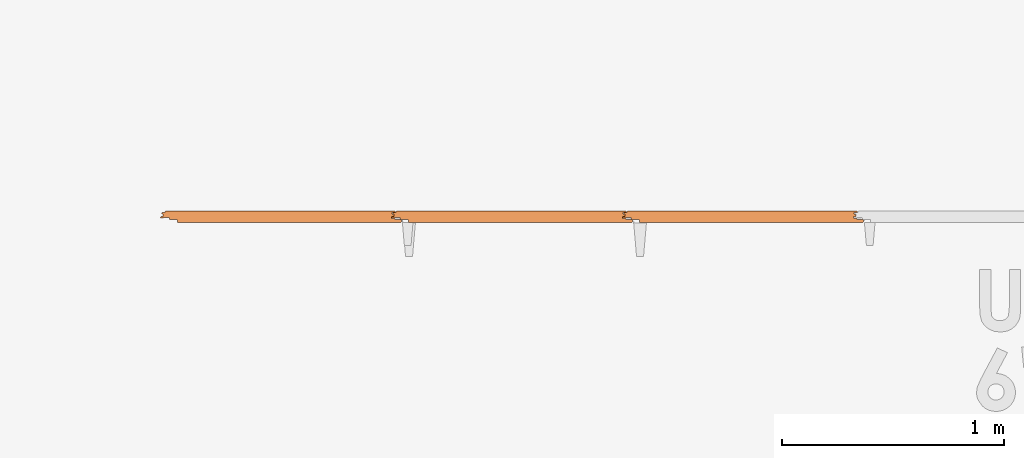
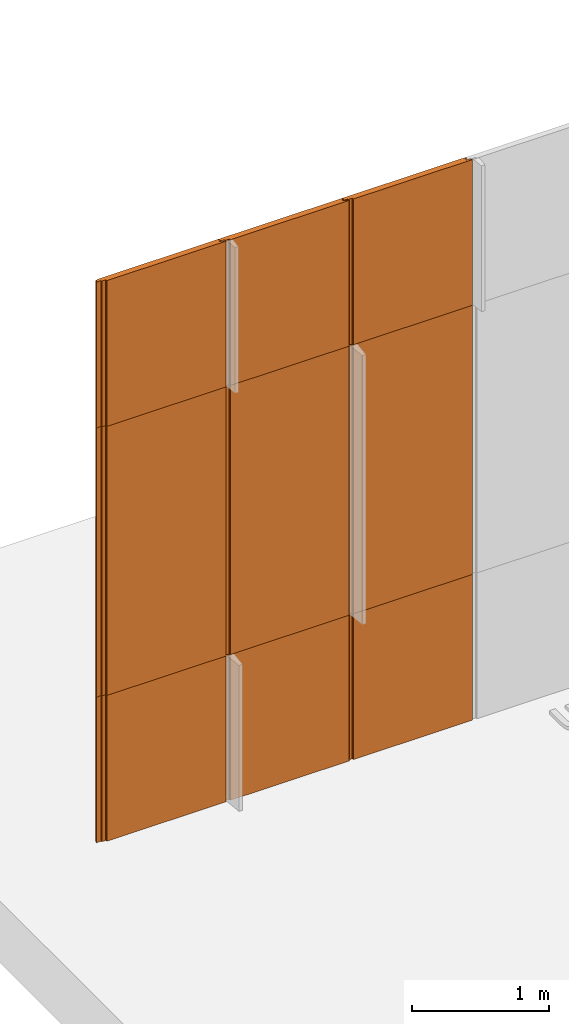
# One storey, part 3 of 6: 9 proxies.
"""IFC2X3 building model written with IfcOpenShell, lengths in millimetres."""

import ifcopenshell
import ifcopenshell.guid

model = None  # the IFC model being written
_history = None  # IfcOwnerHistory: only IFC2X3 demands one
_inside = {}  # id of a spatial element -> (the spatial element, [elements in it])
_under = {}  # id of a project, library or spatial element -> (it, [spatial elements below it])
_declared = {}  # id of a project -> (the project, [libraries it declares])
_typed = {}  # id of a type object -> (the type object, [elements of that type])
_made_of = {}  # id of a material, layer set ... -> (it, [elements and type objects made of it])


def new_model(schema):
    """Start an empty IFC model of exactly this schema.

    Asked for "IFC4X3", IfcOpenShell would pick the latest addendum, in which some entities
    have other attributes; the version numbers below select the first issue.
    IFC2X3 requires an IfcOwnerHistory on every rooted entity: one is made here for all.
    """
    global model, _history
    if schema == "IFC4X3":
        model = ifcopenshell.file(schema_version=(4, 3, 0, 0))
    else:
        model = ifcopenshell.file(schema=schema)
    _inside.clear()
    _under.clear()
    _declared.clear()
    _typed.clear()
    _made_of.clear()
    _history = None
    if model.schema == "IFC2X3":
        org = make("IfcOrganization", Name="unknown")
        user = make(
            "IfcPersonAndOrganization",
            ThePerson=make("IfcPerson", FamilyName="unknown"),
            TheOrganization=org,
        )
        app = make(
            "IfcApplication",
            ApplicationDeveloper=org,
            Version="unknown",
            ApplicationFullName="unknown",
            ApplicationIdentifier="unknown",
        )
        _history = make(
            "IfcOwnerHistory",
            OwningUser=user,
            OwningApplication=app,
            ChangeAction="ADDED",
            CreationDate=0,
        )
    return model


def make(cls, **values):
    """One entity of the class cls with the attributes given. An attribute that is None is left unset."""
    return model.create_entity(
        cls, **{name: value for name, value in values.items() if value is not None}
    )


def entity(cls, *values):
    """Any entity or typed value of the class cls, its attributes in the order of the schema. None: left unset."""
    e = model.create_entity(cls)
    for i, value in enumerate(values):
        if value is not None:
            e[i] = value
    return e


def rooted(cls, **values):
    """An entity with a GlobalId (a new one), such as an element, a storey or a relation."""
    return make(cls, GlobalId=ifcopenshell.guid.new(), OwnerHistory=_history, **values)


def si_unit(unit_type, name, prefix=None):
    """IfcSIUnit, for example si_unit("LENGTHUNIT", "METRE", prefix="MILLI")."""
    return make("IfcSIUnit", UnitType=unit_type, Prefix=prefix, Name=name)


def converted_unit(unit_type, name, factor, base, dimensions=None, offset=None):
    """IfcConversionBasedUnit, such as the inch: factor (a typed value) times the base unit."""
    return make(
        "IfcConversionBasedUnit"
        if offset is None
        else "IfcConversionBasedUnitWithOffset",
        ConversionOffset=offset,
        Dimensions=None
        if dimensions is None
        else entity("IfcDimensionalExponents", *dimensions),
        UnitType=unit_type,
        Name=name,
        ConversionFactor=make(
            "IfcMeasureWithUnit", ValueComponent=factor, UnitComponent=base
        ),
    )


def derived_unit(unit_type, elements):
    """IfcDerivedUnit: a product of units, each with its exponent."""
    return make(
        "IfcDerivedUnit",
        Elements=[
            make("IfcDerivedUnitElement", Unit=unit, Exponent=power)
            for unit, power in elements
        ],
        UnitType=unit_type,
    )


def assignment(units):
    """IfcUnitAssignment: the units of a project."""
    return None if units is None else make("IfcUnitAssignment", Units=units)


def point(xyz):
    """IfcCartesianPoint."""
    return None if xyz is None else make("IfcCartesianPoint", Coordinates=xyz)


def direction(xyz):
    """IfcDirection."""
    return None if xyz is None else make("IfcDirection", DirectionRatios=xyz)


def frame(location, z_axis=None, x_axis=None):
    """IfcAxis2Placement3D, a coordinate frame: its origin and axes. An axis left out is left unset."""
    return make(
        "IfcAxis2Placement3D",
        Location=point(location),
        Axis=direction(z_axis),
        RefDirection=direction(x_axis),
    )


def frame_2d(location, x_axis=None):
    """IfcAxis2Placement2D, a coordinate frame in the plane: its origin and x axis."""
    return make(
        "IfcAxis2Placement2D", Location=point(location), RefDirection=direction(x_axis)
    )


def origin():
    """The frame at (0, 0, 0) with its axes left unset."""
    return frame((0.0, 0.0, 0.0))


def place(relative_to, where):
    """IfcLocalPlacement: puts the frame where relative to a parent placement (None: the world)."""
    return make(
        "IfcLocalPlacement", PlacementRelTo=relative_to, RelativePlacement=where
    )


def context(
    kind, dimensions, precision=None, world=None, true_north=None, identifier=None
):
    """IfcGeometricRepresentationContext, for example the 3D "Model" context."""
    return make(
        "IfcGeometricRepresentationContext",
        ContextIdentifier=identifier,
        ContextType=kind,
        CoordinateSpaceDimension=dimensions,
        Precision=precision,
        WorldCoordinateSystem=world,
        TrueNorth=true_north,
    )


def subcontext(parent, identifier, kind, view, scale=None):
    """IfcGeometricRepresentationSubContext, for example "Body" below "Model"."""
    return make(
        "IfcGeometricRepresentationSubContext",
        ContextIdentifier=identifier,
        ContextType=kind,
        ParentContext=parent,
        TargetScale=scale,
        TargetView=view,
    )


def project(units=None, contexts=None):
    """IfcProject with its units and contexts."""
    return rooted(
        "IfcProject",
        Name="project",
        RepresentationContexts=contexts,
        UnitsInContext=assignment(units),
    )


def spatial(cls, under=None, at=None, **own):
    """A site, building, storey or space (cls), placed at a placement, below another one or the project."""
    s = rooted(cls, ObjectPlacement=at, **own)
    if under is not None:
        _under.setdefault(under.id(), (under, []))[1].append(s)
    return s


def polyline(points):
    """IfcPolyline through the points."""
    return make("IfcPolyline", Points=[point(p) for p in points])


def circle_curve(where, radius):
    """IfcCircle in the frame where."""
    return make("IfcCircle", Position=where, Radius=radius)


def parameter(value):
    """IfcParameterValue: where a trimmed curve begins or ends, as a parameter of its basis curve."""
    return model.create_entity("IfcParameterValue", value)


def trimmed(basis, trim1, trim2, sense, master):
    """IfcTrimmedCurve: the piece of a basis curve between two trims."""
    return make(
        "IfcTrimmedCurve",
        BasisCurve=basis,
        Trim1=trim1,
        Trim2=trim2,
        SenseAgreement=sense,
        MasterRepresentation=master,
    )


def segment(curve, same_sense, transition):
    """IfcCompositeCurveSegment."""
    return make(
        "IfcCompositeCurveSegment",
        Transition=transition,
        SameSense=same_sense,
        ParentCurve=curve,
    )


def composite_curve(segments, self_intersect=None):
    """IfcCompositeCurve: segments joined end to end."""
    return make("IfcCompositeCurve", Segments=segments, SelfIntersect=self_intersect)


def outline(outer, holes=None, kind="AREA"):
    """IfcArbitraryClosedProfileDef: a profile drawn as a closed curve; with holes, ...WithVoids."""
    if holes is None:
        return make("IfcArbitraryClosedProfileDef", ProfileType=kind, OuterCurve=outer)
    return make(
        "IfcArbitraryProfileDefWithVoids",
        ProfileType=kind,
        OuterCurve=outer,
        InnerCurves=holes,
    )


def extrude(swept, where, along, depth):
    """IfcExtrudedAreaSolid: the profile swept, set in the frame where, extruded along a direction by depth."""
    return make(
        "IfcExtrudedAreaSolid",
        SweptArea=swept,
        Position=where,
        ExtrudedDirection=direction(along),
        Depth=depth,
    )


def shape(context_of_items, identifier, shape_type, items):
    """IfcShapeRepresentation: the items that make up one representation, for example the "Body"."""
    return make(
        "IfcShapeRepresentation",
        ContextOfItems=context_of_items,
        RepresentationIdentifier=identifier,
        RepresentationType=shape_type,
        Items=items,
    )


def source(mapping_origin, context_of_items, identifier, shape_type, items):
    """IfcRepresentationMap: a shape defined once, which mapped items show again and again."""
    return make(
        "IfcRepresentationMap",
        MappingOrigin=mapping_origin,
        MappedRepresentation=shape(context_of_items, identifier, shape_type, items),
    )


def transform(
    local_origin,
    x_axis=None,
    y_axis=None,
    z_axis=None,
    scale=None,
    scale2=None,
    scale3=None,
    uniform=True,
):
    """IfcCartesianTransformationOperator3D, or its non-uniform kind. x_axis, y_axis, z_axis: its Axis1, 2, 3."""
    if uniform:
        return make(
            "IfcCartesianTransformationOperator3D",
            Axis1=direction(x_axis),
            Axis2=direction(y_axis),
            LocalOrigin=point(local_origin),
            Scale=scale,
            Axis3=direction(z_axis),
        )
    return make(
        "IfcCartesianTransformationOperator3DnonUniform",
        Axis1=direction(x_axis),
        Axis2=direction(y_axis),
        LocalOrigin=point(local_origin),
        Scale=scale,
        Axis3=direction(z_axis),
        Scale2=scale2,
        Scale3=scale3,
    )


def mapped(mapping_source, mapping_target):
    """IfcMappedItem: shows the shape of a source again, moved by a transform."""
    return make(
        "IfcMappedItem", MappingSource=mapping_source, MappingTarget=mapping_target
    )


def material(Name=None, Category=None):
    """IfcMaterial."""
    return make("IfcMaterial", Name=Name, Category=Category)


def made_of(thing, what):
    """Note that an element or type object is made of a material, layer set ...; save() writes the relation."""
    if what is not None:
        _made_of.setdefault(what.id(), (what, []))[1].append(thing)
    return thing


def type_object(cls, material=None, **own):
    """A type object (cls), such as IfcWallType, which elements share."""
    return made_of(rooted(cls, **own), material)


def type_shapes(of_type, sources):
    """Give a type object the sources (RepresentationMaps) that its elements show as mapped items."""
    of_type.RepresentationMaps = sources


def element(
    cls,
    number,
    at=None,
    inside=None,
    cuts=None,
    type_object=None,
    material=None,
    context=None,
    identifier="Body",
    shape_type=None,
    held_by="IfcProductDefinitionShape",
    body=None,
    shapes=None,
    **own,
):
    """One element of the class cls, such as IfcWall. Its Tag is "e" and its number.

    at: its placement. inside: the storey or other place that contains it. cuts: it is an
    opening in that element (IfcRelVoidsElement). A single representation is given by context,
    identifier, shape_type and body (its items); several are given by shapes. held_by: the class
    of the entity that holds the representations. save() writes the other relations.
    """
    e = rooted(cls, Tag="e%d" % number, ObjectPlacement=at, **own)
    if body is not None:
        shapes = [shape(context, identifier, shape_type, body)]
    if shapes is not None:
        e.Representation = make(held_by, Representations=shapes)
    if inside is not None:
        _inside.setdefault(inside.id(), (inside, []))[1].append(e)
    if cuts is not None:
        rooted(
            "IfcRelVoidsElement", RelatingBuildingElement=cuts, RelatedOpeningElement=e
        )
    if type_object is not None:
        _typed.setdefault(type_object.id(), (type_object, []))[1].append(e)
    return made_of(e, material)


def aggregate(whole, parts):
    """IfcRelAggregates: a whole, such as a stair, and the parts it consists of."""
    return rooted("IfcRelAggregates", RelatingObject=whole, RelatedObjects=parts)


def save(model, path):
    """Write the relations noted so far, then the file.

    IfcRelAggregates (storeys below a building ...), IfcRelContainedInSpatialStructure (elements
    in a storey), IfcRelDefinesByType, IfcRelAssociatesMaterial and IfcRelDeclares: one each for
    every whole, place, type object, material and project.
    """
    for whole, parts in _under.values():
        aggregate(whole, parts)
    for where, things in _inside.values():
        rooted(
            "IfcRelContainedInSpatialStructure",
            RelatedElements=things,
            RelatingStructure=where,
        )
    for kind, things in _typed.values():
        rooted("IfcRelDefinesByType", RelatedObjects=things, RelatingType=kind)
    for what, things in _made_of.values():
        rooted("IfcRelAssociatesMaterial", RelatedObjects=things, RelatingMaterial=what)
    for by, libraries in _declared.values():
        rooted("IfcRelDeclares", RelatingContext=by, RelatedDefinitions=libraries)
    model.write(path)


model = new_model("IFC2X3")

# Units and contexts
model_context = context("Model", 3, precision=0.01, world=origin(), true_north=direction((6.123031769111886e-17, 1.0)))
body_context = subcontext(model_context, "Body", "Model", "MODEL_VIEW")
ifc_project = project(units=[si_unit("LENGTHUNIT", "METRE", prefix="MILLI"), si_unit("AREAUNIT", "SQUARE_METRE"), si_unit("VOLUMEUNIT", "CUBIC_METRE"), converted_unit("PLANEANGLEUNIT", "DEGREE", entity("IfcPlaneAngleMeasure", 0.017453292519943278), si_unit("PLANEANGLEUNIT", "RADIAN"), dimensions=[0, 0, 0, 0, 0, 0, 0]), si_unit("MASSUNIT", "GRAM", prefix="KILO"), derived_unit("MASSDENSITYUNIT", [(si_unit("MASSUNIT", "GRAM", prefix="KILO"), 1), (si_unit("LENGTHUNIT", "METRE"), -3)]), derived_unit("IONCONCENTRATIONUNIT", [(si_unit("MASSUNIT", "GRAM", prefix="KILO"), 1), (si_unit("LENGTHUNIT", "METRE"), -3)]), derived_unit("MOMENTOFINERTIAUNIT", [(si_unit("LENGTHUNIT", "METRE"), 4)]), si_unit("TIMEUNIT", "SECOND"), si_unit("FREQUENCYUNIT", "HERTZ"), si_unit("THERMODYNAMICTEMPERATUREUNIT", "DEGREE_CELSIUS"), derived_unit("THERMALTRANSMITTANCEUNIT", [(si_unit("MASSUNIT", "GRAM", prefix="KILO"), 1), (si_unit("THERMODYNAMICTEMPERATUREUNIT", "KELVIN"), -1), (si_unit("TIMEUNIT", "SECOND"), -3)]), derived_unit("THERMALCONDUCTANCEUNIT", [(si_unit("MASSUNIT", "GRAM", prefix="KILO"), 1), (si_unit("THERMODYNAMICTEMPERATUREUNIT", "KELVIN"), -1), (si_unit("TIMEUNIT", "SECOND"), -3), (si_unit("LENGTHUNIT", "METRE"), 1)]), derived_unit("VOLUMETRICFLOWRATEUNIT", [(si_unit("LENGTHUNIT", "METRE", prefix="DECI"), 3), (si_unit("TIMEUNIT", "SECOND"), -1)]), derived_unit("MASSFLOWRATEUNIT", [(si_unit("MASSUNIT", "GRAM", prefix="KILO"), 1), (si_unit("TIMEUNIT", "SECOND"), -1)]), derived_unit("ROTATIONALFREQUENCYUNIT", [(si_unit("TIMEUNIT", "SECOND"), -1)]), si_unit("ELECTRICCURRENTUNIT", "AMPERE"), si_unit("ELECTRICVOLTAGEUNIT", "VOLT"), si_unit("POWERUNIT", "WATT"), si_unit("FORCEUNIT", "NEWTON", prefix="KILO"), si_unit("ILLUMINANCEUNIT", "LUX"), si_unit("LUMINOUSFLUXUNIT", "LUMEN"), si_unit("LUMINOUSINTENSITYUNIT", "CANDELA"), si_unit("ENERGYUNIT", "JOULE"), derived_unit("USERDEFINED", [(si_unit("MASSUNIT", "GRAM", prefix="KILO"), -1), (si_unit("LENGTHUNIT", "METRE"), -2), (si_unit("TIMEUNIT", "SECOND"), 3), (si_unit("LUMINOUSFLUXUNIT", "LUMEN"), 1)]), derived_unit("USERDEFINED", [(si_unit("MASSUNIT", "GRAM", prefix="KILO"), 1), (si_unit("TIMEUNIT", "SECOND"), -3), (si_unit("LENGTHUNIT", "METRE"), 3), (si_unit("ELECTRICCURRENTUNIT", "AMPERE"), -2)]), derived_unit("SOUNDPOWERUNIT", [(si_unit("MASSUNIT", "GRAM", prefix="KILO"), 1), (si_unit("TIMEUNIT", "SECOND"), -3), (si_unit("LENGTHUNIT", "METRE"), 2)]), derived_unit("SOUNDPRESSUREUNIT", [(si_unit("MASSUNIT", "GRAM", prefix="KILO"), 1), (si_unit("LENGTHUNIT", "METRE"), -1), (si_unit("TIMEUNIT", "SECOND"), -2)]), derived_unit("LINEARVELOCITYUNIT", [(si_unit("LENGTHUNIT", "METRE"), 1), (si_unit("TIMEUNIT", "SECOND"), -1)]), si_unit("PRESSUREUNIT", "PASCAL"), derived_unit("USERDEFINED", [(si_unit("MASSUNIT", "GRAM", prefix="KILO"), 1), (si_unit("LENGTHUNIT", "METRE"), -2), (si_unit("TIMEUNIT", "SECOND"), -2)]), derived_unit("LINEARFORCEUNIT", [(si_unit("MASSUNIT", "GRAM", prefix="KILO"), 1), (si_unit("TIMEUNIT", "SECOND"), -2)]), derived_unit("PLANARFORCEUNIT", [(si_unit("MASSUNIT", "GRAM", prefix="KILO"), 1), (si_unit("LENGTHUNIT", "METRE"), -1), (si_unit("TIMEUNIT", "SECOND"), -2)]), derived_unit("SPECIFICHEATCAPACITYUNIT", [(si_unit("THERMODYNAMICTEMPERATUREUNIT", "KELVIN"), -1), (si_unit("LENGTHUNIT", "METRE"), 2), (si_unit("TIMEUNIT", "SECOND"), -2)]), derived_unit("HEATFLUXDENSITYUNIT", [(si_unit("MASSUNIT", "GRAM", prefix="KILO"), 1), (si_unit("TIMEUNIT", "SECOND"), -3)]), derived_unit("HEATINGVALUEUNIT", [(si_unit("LENGTHUNIT", "METRE"), 2), (si_unit("TIMEUNIT", "SECOND"), -2)]), derived_unit("VAPORPERMEABILITYUNIT", [(si_unit("LENGTHUNIT", "METRE"), -1), (si_unit("TIMEUNIT", "SECOND"), 1)]), derived_unit("DYNAMICVISCOSITYUNIT", [(si_unit("MASSUNIT", "GRAM", prefix="KILO"), 1), (si_unit("TIMEUNIT", "SECOND"), -1), (si_unit("LENGTHUNIT", "METRE"), -1)]), derived_unit("THERMALEXPANSIONCOEFFICIENTUNIT", [(si_unit("THERMODYNAMICTEMPERATUREUNIT", "KELVIN"), -1)]), derived_unit("MODULUSOFELASTICITYUNIT", [(si_unit("MASSUNIT", "GRAM", prefix="KILO"), 1), (si_unit("LENGTHUNIT", "METRE"), -1), (si_unit("TIMEUNIT", "SECOND"), -2)]), derived_unit("ISOTHERMALMOISTURECAPACITYUNIT", [(si_unit("MASSUNIT", "GRAM", prefix="KILO"), -1), (si_unit("LENGTHUNIT", "METRE"), 3)]), derived_unit("MOISTUREDIFFUSIVITYUNIT", [(si_unit("TIMEUNIT", "SECOND"), -1), (si_unit("LENGTHUNIT", "METRE"), 2)]), derived_unit("MASSPERLENGTHUNIT", [(si_unit("MASSUNIT", "GRAM", prefix="KILO"), 1), (si_unit("LENGTHUNIT", "METRE"), -1)]), derived_unit("THERMALRESISTANCEUNIT", [(si_unit("MASSUNIT", "GRAM", prefix="KILO"), -1), (si_unit("TIMEUNIT", "SECOND"), 3), (si_unit("THERMODYNAMICTEMPERATUREUNIT", "KELVIN"), 1)]), derived_unit("ACCELERATIONUNIT", [(si_unit("LENGTHUNIT", "METRE"), 1), (si_unit("TIMEUNIT", "SECOND"), -2)]), derived_unit("ANGULARVELOCITYUNIT", [(si_unit("TIMEUNIT", "SECOND"), -1), (si_unit("PLANEANGLEUNIT", "RADIAN"), 1)]), derived_unit("LINEARSTIFFNESSUNIT", [(si_unit("MASSUNIT", "GRAM", prefix="KILO"), 1), (si_unit("TIMEUNIT", "SECOND"), -2)]), derived_unit("WARPINGCONSTANTUNIT", [(si_unit("LENGTHUNIT", "METRE"), 6)]), derived_unit("LINEARMOMENTUNIT", [(si_unit("MASSUNIT", "GRAM", prefix="KILO"), 1), (si_unit("LENGTHUNIT", "METRE"), 1), (si_unit("TIMEUNIT", "SECOND"), -2)]), derived_unit("TORQUEUNIT", [(si_unit("MASSUNIT", "GRAM", prefix="KILO"), 1), (si_unit("LENGTHUNIT", "METRE"), 2), (si_unit("TIMEUNIT", "SECOND"), -2)])], contexts=[model_context])

# Site, building, storey
site_placement = place(None, origin())
site = spatial("IfcSite", under=ifc_project, at=site_placement, CompositionType="ELEMENT")
building_placement = place(site_placement, origin())
building = spatial("IfcBuilding", under=site, at=building_placement, Name="de", CompositionType="ELEMENT")
storey_placement = place(building_placement, origin())
storey = spatial("IfcBuildingStorey", under=building, at=storey_placement, CompositionType="ELEMENT", Elevation=0.0)

# Proxies
ifc_material = material(Name="KSI_RAL9003")
building_element_proxy_type_1 = type_object("IfcBuildingElementProxyType", Name="Painel Evolution:Painel Evolution", PredefinedType="NOTDEFINED", material=ifc_material)
shared_shape_1 = source(origin(), body_context, "Body", "SweptSolid", [
    extrude(outline(composite_curve([segment(trimmed(circle_curve(frame_2d((-541.6373700065079, 10.459449795313603), x_axis=(-1.0, 0.0)), 1.5999999047686129), [parameter(279.9999998873789)], [parameter(358.50454829316124)], True, "PARAMETER"), True, "CONTINUOUS"), segment(polyline([(-543.2368249510248, 10.501205941207395), (-543.2368249510248, 3.880596964632579)]), True, "CONTINUOUS"), segment(trimmed(circle_curve(frame_2d((-542.1914107086996, 3.880596964632576), x_axis=(-1.0, 0.0)), 1.0454142423252974), [parameter(359.9999999999996)], [parameter(90.00000000000009)], True, "PARAMETER"), True, "CONTINUOUS"), segment(polyline([(-542.1914107086996, 2.83518272230729), (-534.2753031299127, 2.835182722321888)]), True, "CONTINUOUS"), segment(trimmed(circle_curve(frame_2d((-534.2753031299127, 0.485182810658933), x_axis=(-1.0, 0.0)), 2.3499999116629553), [parameter(180.00000000000043)], [parameter(269.9999999999999)], True, "PARAMETER"), False, "CONTINUOUS"), segment(polyline([(-531.9253032182644, 0.4851828106589372), (-531.9253032182644, -3.9178716254091968)]), True, "CONTINUOUS"), segment(trimmed(circle_curve(frame_2d((-534.275303129929, -3.917871625409184), x_axis=(-1.0, 0.0)), 2.3499999116645798), [parameter(90.00000000000009)], [parameter(180.0)], True, "PARAMETER"), False, "CONTINUOUS"), segment(polyline([(-534.275303129929, -6.267871537073788), (-544.9447939910186, -6.267871537074008)]), True, "CONTINUOUS"), segment(trimmed(circle_curve(frame_2d((-544.9447939910186, -8.667871537069942), x_axis=(-1.0, 0.0)), 2.399999999995935), [parameter(269.9999999999999)], [parameter(359.99999999999966)], True, "PARAMETER"), True, "CONTINUOUS"), segment(polyline([(-547.3447939910149, -8.667871537069942), (-547.3447939910149, -10.667871311477809)]), True, "CONTINUOUS"), segment(trimmed(circle_curve(frame_2d((-548.9447939910189, -10.667871311477805), x_axis=(-1.0, 0.0)), 1.6000000000039678), [parameter(90.00000000000009)], [parameter(180.0000000000002)], True, "PARAMETER"), False, "CONTINUOUS"), segment(polyline([(-548.9447939910189, -12.267871311481763), (-572.3355503541303, -12.26787131148627)]), True, "CONTINUOUS"), segment(trimmed(circle_curve(frame_2d((-572.3355503541303, -15.967871172331035), x_axis=(-1.0, 0.0)), 3.699999860844765), [parameter(269.9999999999999)], [parameter(350.4980187502896)], True, "PARAMETER"), True, "CONTINUOUS"), segment(polyline([(-575.9847858236225, -15.357068865127594), (-576.4262167541286, -20.400087371498177)]), True, "CONTINUOUS"), segment(trimmed(circle_curve(frame_2d((-572.8754972220172, -20.700390565940353), x_axis=(-1.0, 0.0)), 3.5633960212569518), [parameter(355.16569651713564)], [parameter(88.83791988883837)], True, "PARAMETER"), True, "CONTINUOUS"), segment(polyline([(-572.9477655073729, -24.26305368488658), (429.0782903905062, -24.26305368490059)]), True, "CONTINUOUS"), segment(trimmed(circle_curve(frame_2d((429.02661432000133, -21.373687559574048), x_axis=(-1.0, 0.0)), 2.889828199469197), [parameter(91.024620965678)], [parameter(174.99921945634426)], True, "PARAMETER"), True, "CONTINUOUS"), segment(polyline([(431.90544241925767, -21.625591901172886), (432.65194514225794, -13.094365331982997)]), True, "CONTINUOUS"), segment(trimmed(circle_curve(frame_2d((434.6718091241544, -13.271108258981247), x_axis=(-1.0, 0.0)), 2.0275819508977904), [parameter(322.50238491495514)], [parameter(354.9992194748408)], True, "PARAMETER"), False, "CONTINUOUS"), segment(trimmed(circle_curve(frame_2d((434.6499261921662, -13.25431834245234), x_axis=(-1.0, 0.0)), 2.000000000331924), [parameter(269.7752197054467)], [parameter(322.50238490067886)], True, "PARAMETER"), False, "CONTINUOUS"), segment(polyline([(434.6577724845074, -11.254333733262063), (464.6446978830772, -11.254333733258877)]), True, "CONTINUOUS"), segment(trimmed(circle_curve(frame_2d((464.6446978830757, -8.454333717516795), x_axis=(-1.0, 0.0)), 2.8000000157420852), [parameter(90.00000000003057)], [parameter(180.00000000002854)], True, "PARAMETER"), True, "CONTINUOUS"), segment(polyline([(467.4446978988198, -8.45433371751389), (467.44469789904696, -6.163773190028205)]), True, "CONTINUOUS"), segment(trimmed(circle_curve(frame_2d((470.4446979072005, -6.163773190028211), x_axis=(-1.0, 0.0)), 3.000000008153628), [parameter(269.9999999999947)], [parameter(4.0711099922733055e-13)], True, "PARAMETER"), False, "CONTINUOUS"), segment(polyline([(470.4446979072011, -3.1637731816474877), (492.4821726913916, -3.1637731816475423)]), True, "CONTINUOUS"), segment(trimmed(circle_curve(frame_2d((492.4821726913916, -4.763773183527278), x_axis=(-1.0, 0.0)), 1.6000000018797356), [parameter(221.0795546756581)], [parameter(270.00000000000233)], True, "PARAMETER"), False, "CONTINUOUS"), segment(trimmed(circle_curve(frame_2d((496.43523715110086, -1.9925479235228443), x_axis=(-1.0, 0.0)), 3.2409633915334344), [parameter(32.05017476117218)], [parameter(61.522805713472586)], True, "PARAMETER"), True, "CONTINUOUS"), segment(trimmed(circle_curve(frame_2d((496.00254394635044, -2.714863509877051), x_axis=(-1.0, 0.0)), 2.4000000000014894), [parameter(62.38069466751207)], [parameter(92.2671756846998)], True, "PARAMETER"), True, "CONTINUOUS"), segment(polyline([(496.0974863986537, -5.11298484349589), (504.442623351026, -5.112984843495904)]), True, "CONTINUOUS"), segment(trimmed(circle_curve(frame_2d((504.4426233510259, -1.8442935298604415), x_axis=(-1.0, 0.0)), 3.268691313635463), [parameter(90.00000000000126)], [parameter(266.64922463269517)], True, "PARAMETER"), True, "CONTINUOUS"), segment(polyline([(504.63367421393616, 1.4188096667328296), (496.7914226707592, 1.4188096667328491)]), True, "CONTINUOUS"), segment(polyline([(496.7914226707592, 1.4188096667328491), (496.79142267075923, 13.229214081882997)]), True, "CONTINUOUS"), segment(polyline([(496.79142267075923, 13.229214081882997), (500.32479033585236, 13.22921408188327)]), True, "CONTINUOUS"), segment(trimmed(circle_curve(frame_2d((499.51496654021736, 16.736946315110515), x_axis=(-1.0, 0.0)), 3.599999999999723), [parameter(102.99999999995242)], [parameter(269.99999999999886)], True, "PARAMETER"), True, "CONTINUOUS"), segment(polyline([(499.5149665402175, 20.336946315110506), (489.7149665402197, 20.33694631511163)]), True, "CONTINUOUS"), segment(trimmed(circle_curve(frame_2d((489.7149665402197, 22.336946315111717), x_axis=(-1.0, 0.0)), 2.0000000000000866), [parameter(3.5622212432391423e-13)], [parameter(90.00000000000202)], True, "PARAMETER"), False, "CONTINUOUS"), segment(polyline([(487.71496654021854, 22.336946315111724), (487.71496654021854, 23.736946315111506)]), True, "CONTINUOUS"), segment(trimmed(circle_curve(frame_2d((485.7149665402189, 23.73694631511151), x_axis=(-1.0, 0.0)), 1.9999999999995453), [parameter(179.99999999999983)], [parameter(269.99999999999795)], True, "PARAMETER"), True, "CONTINUOUS"), segment(polyline([(485.7149665402189, 25.736946315111073), (-547.7850334597792, 25.736946315115553)]), True, "CONTINUOUS"), segment(trimmed(circle_curve(frame_2d((-547.7850334597792, 23.23694631511558), x_axis=(-1.0, 0.0)), 2.499999999999973), [parameter(269.9999999999999)], [parameter(90.00000000000009)], True, "PARAMETER"), True, "CONTINUOUS"), segment(polyline([(-547.7850334597794, 20.736946315117518), (-538.5134802227543, 20.736946315115397)]), True, "CONTINUOUS"), segment(trimmed(circle_curve(frame_2d((-538.5134802227543, 16.38604421100607), x_axis=(-1.0, 0.0)), 4.350902104109325), [parameter(90.00000000000009)], [parameter(269.9999999999999)], True, "PARAMETER"), False, "CONTINUOUS"), segment(polyline([(-538.5134802227543, 12.03514210689464), (-541.9152070711411, 12.03514210689464)]), True, "CONTINUOUS")], self_intersect=False)), frame((-30.32409595977936, -0.7369463151145117, 0.0), z_axis=(0.0, 0.0, -1.0), x_axis=(-1.0, 0.0, 0.0)), (0.0, 0.0, -1.0), 1300.0000000000005),
])
type_shapes(building_element_proxy_type_1, [shared_shape_1])
for number, where, name in (
    (1, (-2130.051034202846, 792.6007792258564, 0.0), "Painel Evolution:Painel Evolution"),
    (2, (-4210.051034355246, 792.6007792258614, 0.0), "Painel Evolution:Painel Evolution"),
    (3, (-3170.0510342028456, 792.6007792258589, 0.0), "Painel Evolution:Painel Evolution"),
    (4, (-2130.051034202846, 792.6007792258564, 3700.0), "Painel Evolution:Painel Evolution"),
    (5, (-3170.0510342028456, 792.6007792258589, 3700.0), "Painel Evolution:Painel Evolution"),
    (6, (-4210.051034355246, 792.6007792258614, 3700.0), "Painel Evolution:Painel Evolution"),
):
    element("IfcBuildingElementProxy", number, at=place(storey_placement, frame(where)), inside=storey, type_object=building_element_proxy_type_1, material=ifc_material, Name=name, ObjectType="Painel Evolution:Painel Evolution", context=body_context, shape_type="MappedRepresentation", body=[
        mapped(shared_shape_1, transform((0.0, 0.0, 0.0), scale=1.0)),
    ])
building_element_proxy_type_2 = type_object("IfcBuildingElementProxyType", Name="Painel Evolution:Painel Evolution", PredefinedType="NOTDEFINED", material=ifc_material)
shared_shape_2 = source(origin(), body_context, "Body", "SweptSolid", [
    extrude(outline(composite_curve([segment(trimmed(circle_curve(frame_2d((-541.6373700065079, 10.459449795313603), x_axis=(-1.0, 0.0)), 1.5999999047686129), [parameter(279.9999998873789)], [parameter(358.50454829316124)], True, "PARAMETER"), True, "CONTINUOUS"), segment(polyline([(-543.2368249510248, 10.501205941207395), (-543.2368249510248, 3.880596964632579)]), True, "CONTINUOUS"), segment(trimmed(circle_curve(frame_2d((-542.1914107086996, 3.880596964632576), x_axis=(-1.0, 0.0)), 1.0454142423252974), [parameter(359.9999999999996)], [parameter(90.00000000000009)], True, "PARAMETER"), True, "CONTINUOUS"), segment(polyline([(-542.1914107086996, 2.83518272230729), (-534.2753031299127, 2.835182722321888)]), True, "CONTINUOUS"), segment(trimmed(circle_curve(frame_2d((-534.2753031299127, 0.485182810658933), x_axis=(-1.0, 0.0)), 2.3499999116629553), [parameter(180.00000000000043)], [parameter(269.9999999999999)], True, "PARAMETER"), False, "CONTINUOUS"), segment(polyline([(-531.9253032182644, 0.4851828106589372), (-531.9253032182644, -3.9178716254091968)]), True, "CONTINUOUS"), segment(trimmed(circle_curve(frame_2d((-534.275303129929, -3.917871625409184), x_axis=(-1.0, 0.0)), 2.3499999116645798), [parameter(90.00000000000009)], [parameter(180.0)], True, "PARAMETER"), False, "CONTINUOUS"), segment(polyline([(-534.275303129929, -6.267871537073788), (-544.9447939910186, -6.267871537074008)]), True, "CONTINUOUS"), segment(trimmed(circle_curve(frame_2d((-544.9447939910186, -8.667871537069942), x_axis=(-1.0, 0.0)), 2.399999999995935), [parameter(269.9999999999999)], [parameter(359.99999999999966)], True, "PARAMETER"), True, "CONTINUOUS"), segment(polyline([(-547.3447939910149, -8.667871537069942), (-547.3447939910149, -10.667871311477809)]), True, "CONTINUOUS"), segment(trimmed(circle_curve(frame_2d((-548.9447939910189, -10.667871311477805), x_axis=(-1.0, 0.0)), 1.6000000000039678), [parameter(90.00000000000009)], [parameter(180.0000000000002)], True, "PARAMETER"), False, "CONTINUOUS"), segment(polyline([(-548.9447939910189, -12.267871311481763), (-572.3355503541303, -12.26787131148627)]), True, "CONTINUOUS"), segment(trimmed(circle_curve(frame_2d((-572.3355503541303, -15.967871172331035), x_axis=(-1.0, 0.0)), 3.699999860844765), [parameter(269.9999999999999)], [parameter(350.4980187502896)], True, "PARAMETER"), True, "CONTINUOUS"), segment(polyline([(-575.9847858236225, -15.357068865127594), (-576.4262167541286, -20.400087371498177)]), True, "CONTINUOUS"), segment(trimmed(circle_curve(frame_2d((-572.8754972220172, -20.700390565940353), x_axis=(-1.0, 0.0)), 3.5633960212569518), [parameter(355.16569651713564)], [parameter(88.83791988883837)], True, "PARAMETER"), True, "CONTINUOUS"), segment(polyline([(-572.9477655073729, -24.26305368488658), (429.0782903905062, -24.26305368490059)]), True, "CONTINUOUS"), segment(trimmed(circle_curve(frame_2d((429.02661432000133, -21.373687559574048), x_axis=(-1.0, 0.0)), 2.889828199469197), [parameter(91.024620965678)], [parameter(174.99921945634426)], True, "PARAMETER"), True, "CONTINUOUS"), segment(polyline([(431.90544241925767, -21.625591901172886), (432.65194514225794, -13.094365331982997)]), True, "CONTINUOUS"), segment(trimmed(circle_curve(frame_2d((434.6718091241544, -13.271108258981247), x_axis=(-1.0, 0.0)), 2.0275819508977904), [parameter(322.50238491495514)], [parameter(354.9992194748408)], True, "PARAMETER"), False, "CONTINUOUS"), segment(trimmed(circle_curve(frame_2d((434.6499261921662, -13.25431834245234), x_axis=(-1.0, 0.0)), 2.000000000331924), [parameter(269.7752197054467)], [parameter(322.50238490067886)], True, "PARAMETER"), False, "CONTINUOUS"), segment(polyline([(434.6577724845074, -11.254333733262063), (464.6446978830772, -11.254333733258877)]), True, "CONTINUOUS"), segment(trimmed(circle_curve(frame_2d((464.6446978830757, -8.454333717516795), x_axis=(-1.0, 0.0)), 2.8000000157420852), [parameter(90.00000000003057)], [parameter(180.00000000002854)], True, "PARAMETER"), True, "CONTINUOUS"), segment(polyline([(467.4446978988198, -8.45433371751389), (467.44469789904696, -6.163773190028205)]), True, "CONTINUOUS"), segment(trimmed(circle_curve(frame_2d((470.4446979072005, -6.163773190028211), x_axis=(-1.0, 0.0)), 3.000000008153628), [parameter(269.9999999999947)], [parameter(4.0711099922733055e-13)], True, "PARAMETER"), False, "CONTINUOUS"), segment(polyline([(470.4446979072011, -3.1637731816474877), (492.4821726913916, -3.1637731816475423)]), True, "CONTINUOUS"), segment(trimmed(circle_curve(frame_2d((492.4821726913916, -4.763773183527278), x_axis=(-1.0, 0.0)), 1.6000000018797356), [parameter(221.0795546756581)], [parameter(270.00000000000233)], True, "PARAMETER"), False, "CONTINUOUS"), segment(trimmed(circle_curve(frame_2d((496.43523715110086, -1.9925479235228443), x_axis=(-1.0, 0.0)), 3.2409633915334344), [parameter(32.05017476117218)], [parameter(61.522805713472586)], True, "PARAMETER"), True, "CONTINUOUS"), segment(trimmed(circle_curve(frame_2d((496.00254394635044, -2.714863509877051), x_axis=(-1.0, 0.0)), 2.4000000000014894), [parameter(62.38069466751207)], [parameter(92.2671756846998)], True, "PARAMETER"), True, "CONTINUOUS"), segment(polyline([(496.0974863986537, -5.11298484349589), (504.442623351026, -5.112984843495904)]), True, "CONTINUOUS"), segment(trimmed(circle_curve(frame_2d((504.4426233510259, -1.8442935298604415), x_axis=(-1.0, 0.0)), 3.268691313635463), [parameter(90.00000000000126)], [parameter(266.64922463269517)], True, "PARAMETER"), True, "CONTINUOUS"), segment(polyline([(504.63367421393616, 1.4188096667328296), (496.7914226707592, 1.4188096667328491)]), True, "CONTINUOUS"), segment(polyline([(496.7914226707592, 1.4188096667328491), (496.79142267075923, 13.229214081882997)]), True, "CONTINUOUS"), segment(polyline([(496.79142267075923, 13.229214081882997), (500.32479033585236, 13.22921408188327)]), True, "CONTINUOUS"), segment(trimmed(circle_curve(frame_2d((499.51496654021736, 16.736946315110515), x_axis=(-1.0, 0.0)), 3.599999999999723), [parameter(102.99999999995242)], [parameter(269.99999999999886)], True, "PARAMETER"), True, "CONTINUOUS"), segment(polyline([(499.5149665402175, 20.336946315110506), (489.7149665402197, 20.33694631511163)]), True, "CONTINUOUS"), segment(trimmed(circle_curve(frame_2d((489.7149665402197, 22.336946315111717), x_axis=(-1.0, 0.0)), 2.0000000000000866), [parameter(3.5622212432391423e-13)], [parameter(90.00000000000202)], True, "PARAMETER"), False, "CONTINUOUS"), segment(polyline([(487.71496654021854, 22.336946315111724), (487.71496654021854, 23.736946315111506)]), True, "CONTINUOUS"), segment(trimmed(circle_curve(frame_2d((485.7149665402189, 23.73694631511151), x_axis=(-1.0, 0.0)), 1.9999999999995453), [parameter(179.99999999999983)], [parameter(269.99999999999795)], True, "PARAMETER"), True, "CONTINUOUS"), segment(polyline([(485.7149665402189, 25.736946315111073), (-547.7850334597792, 25.736946315115553)]), True, "CONTINUOUS"), segment(trimmed(circle_curve(frame_2d((-547.7850334597792, 23.23694631511558), x_axis=(-1.0, 0.0)), 2.499999999999973), [parameter(269.9999999999999)], [parameter(90.00000000000009)], True, "PARAMETER"), True, "CONTINUOUS"), segment(polyline([(-547.7850334597794, 20.736946315117518), (-538.5134802227543, 20.736946315115397)]), True, "CONTINUOUS"), segment(trimmed(circle_curve(frame_2d((-538.5134802227543, 16.38604421100607), x_axis=(-1.0, 0.0)), 4.350902104109325), [parameter(90.00000000000009)], [parameter(269.9999999999999)], True, "PARAMETER"), False, "CONTINUOUS"), segment(polyline([(-538.5134802227543, 12.03514210689464), (-541.9152070711411, 12.03514210689464)]), True, "CONTINUOUS")], self_intersect=False)), frame((-30.32409595977936, -0.7369463151145117, 0.0), z_axis=(0.0, 0.0, -1.0), x_axis=(-1.0, 0.0, 0.0)), (0.0, 0.0, -1.0), 2400.0000000000005),
])
type_shapes(building_element_proxy_type_2, [shared_shape_2])
for number, where, name in (
    (7, (-4210.051034355246, 792.6007792258614, 1300.0), "Painel Evolution:Painel Evolution"),
    (8, (-2130.051034202846, 792.6007792258564, 1300.0), "Painel Evolution:Painel Evolution"),
    (9, (-3170.0510342028456, 792.6007792258589, 1300.0), "Painel Evolution:Painel Evolution"),
):
    element("IfcBuildingElementProxy", number, at=place(storey_placement, frame(where)), inside=storey, type_object=building_element_proxy_type_2, material=ifc_material, Name=name, ObjectType="Painel Evolution:Painel Evolution", context=body_context, shape_type="MappedRepresentation", body=[
        mapped(shared_shape_2, transform((0.0, 0.0, 0.0), scale=1.0)),
    ])

save(model, "model.ifc")
